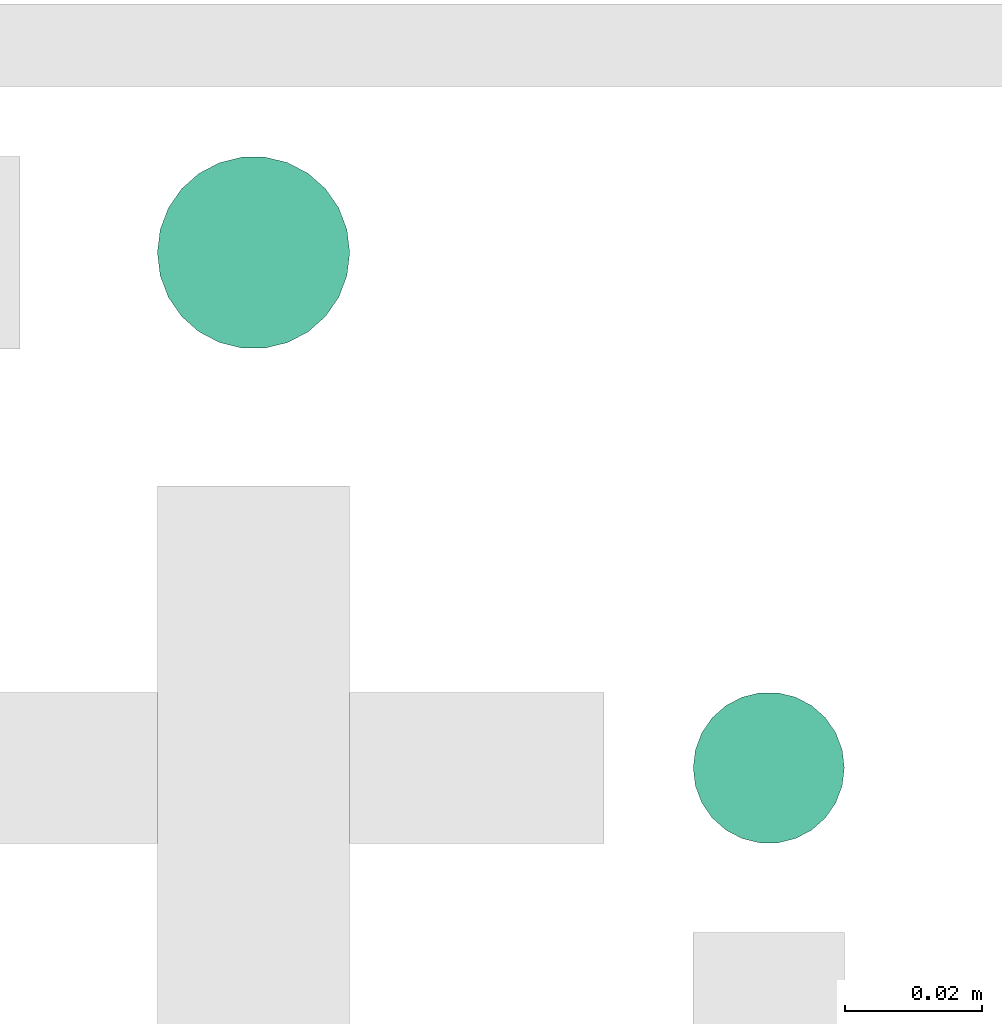
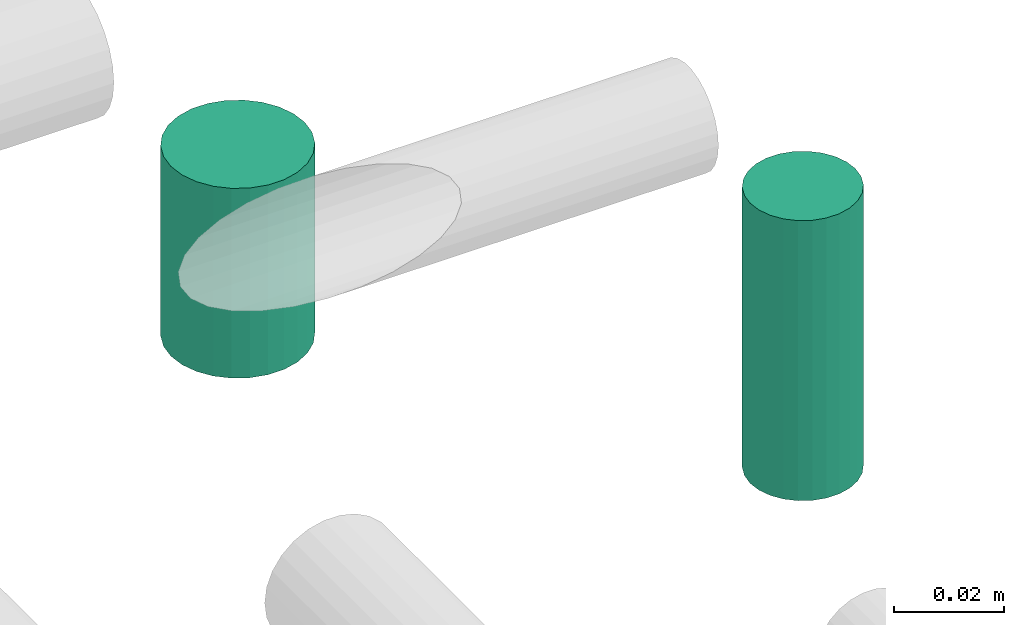
# One storey, part 312 of 331: 2 flow segments.
"""IFC2X3 building model written with IfcOpenShell, lengths in millimetres."""

from ifc_helpers import new_model, entity, si_unit, converted_unit, derived_unit, direction, frame, frame_2d, origin, origin_2d_with_axis, place, context, subcontext, project, spatial, circle, extrude, type_object, element, save


model = new_model("IFC2X3")

# Units and contexts
model_context = context("Model", 3, precision=0.01, world=origin(), true_north=direction((6.12303176911189e-17, 1.0)))
body_context = subcontext(model_context, "Body", "Model", "MODEL_VIEW")
ifc_project = project(units=[si_unit("LENGTHUNIT", "METRE", prefix="MILLI"), si_unit("AREAUNIT", "SQUARE_METRE"), si_unit("VOLUMEUNIT", "CUBIC_METRE"), converted_unit("PLANEANGLEUNIT", "DEGREE", entity("IfcRatioMeasure", 0.0174532925199433), si_unit("PLANEANGLEUNIT", "RADIAN"), dimensions=[0, 0, 0, 0, 0, 0, 0]), si_unit("MASSUNIT", "GRAM", prefix="KILO"), derived_unit("MASSDENSITYUNIT", [(si_unit("MASSUNIT", "GRAM", prefix="KILO"), 1), (si_unit("LENGTHUNIT", "METRE"), -3)]), derived_unit("MOMENTOFINERTIAUNIT", [(si_unit("LENGTHUNIT", "METRE"), 4)]), si_unit("TIMEUNIT", "SECOND"), si_unit("FREQUENCYUNIT", "HERTZ"), si_unit("THERMODYNAMICTEMPERATUREUNIT", "DEGREE_CELSIUS"), derived_unit("THERMALTRANSMITTANCEUNIT", [(si_unit("MASSUNIT", "GRAM", prefix="KILO"), 1), (si_unit("THERMODYNAMICTEMPERATUREUNIT", "KELVIN"), -1), (si_unit("TIMEUNIT", "SECOND"), -3)]), derived_unit("VOLUMETRICFLOWRATEUNIT", [(si_unit("LENGTHUNIT", "METRE"), 3), (si_unit("TIMEUNIT", "SECOND"), -1)]), derived_unit("MASSFLOWRATEUNIT", [(si_unit("MASSUNIT", "GRAM", prefix="KILO"), 1), (si_unit("TIMEUNIT", "SECOND"), -1)]), derived_unit("ROTATIONALFREQUENCYUNIT", [(si_unit("TIMEUNIT", "SECOND"), -1)]), si_unit("ELECTRICCURRENTUNIT", "AMPERE"), si_unit("ELECTRICVOLTAGEUNIT", "VOLT"), si_unit("POWERUNIT", "WATT"), si_unit("FORCEUNIT", "NEWTON", prefix="KILO"), si_unit("ILLUMINANCEUNIT", "LUX"), si_unit("LUMINOUSFLUXUNIT", "LUMEN"), si_unit("LUMINOUSINTENSITYUNIT", "CANDELA"), derived_unit("USERDEFINED", [(si_unit("MASSUNIT", "GRAM", prefix="KILO"), -1), (si_unit("LENGTHUNIT", "METRE"), -2), (si_unit("TIMEUNIT", "SECOND"), 3), (si_unit("LUMINOUSFLUXUNIT", "LUMEN"), 1)]), derived_unit("LINEARVELOCITYUNIT", [(si_unit("LENGTHUNIT", "METRE"), 1), (si_unit("TIMEUNIT", "SECOND"), -1)]), si_unit("PRESSUREUNIT", "PASCAL"), derived_unit("USERDEFINED", [(si_unit("LENGTHUNIT", "METRE"), -2), (si_unit("MASSUNIT", "GRAM", prefix="KILO"), 1), (si_unit("TIMEUNIT", "SECOND"), -2)]), derived_unit("LINEARFORCEUNIT", [(si_unit("MASSUNIT", "GRAM", prefix="KILO"), 1), (si_unit("LENGTHUNIT", "METRE"), 1), (si_unit("TIMEUNIT", "SECOND"), -2), (si_unit("LENGTHUNIT", "METRE"), -1)]), derived_unit("PLANARFORCEUNIT", [(si_unit("MASSUNIT", "GRAM", prefix="KILO"), 1), (si_unit("LENGTHUNIT", "METRE"), 1), (si_unit("TIMEUNIT", "SECOND"), -2), (si_unit("LENGTHUNIT", "METRE"), -2)])], contexts=[model_context])

# Site, building, storey
site_placement = place(None, frame((0.0, -0.00077364408347762, 0.0)))
site = spatial("IfcSite", under=ifc_project, at=site_placement, CompositionType="ELEMENT")
building_placement = place(site_placement, origin())
building = spatial("IfcBuilding", under=site, at=building_placement, CompositionType="ELEMENT")
storey_placement = place(building_placement, origin())
storey = spatial("IfcBuildingStorey", under=building, at=storey_placement, CompositionType="ELEMENT", Elevation=0.0)

# Flow segments
pipe_segment_type = type_object("IfcPipeSegmentType", PredefinedType="NOTDEFINED")
flow_segment_1_placement = place(storey_placement, frame((65559.5166110417, 8569.21546224655, 18484.0)))
element("IfcFlowSegment", 1, at=flow_segment_1_placement, inside=storey, type_object=pipe_segment_type, context=body_context, shape_type="SweptSolid", body=[
    extrude(circle(Radius=14.0, at=frame_2d((0.0, -1.08286712929839e-12), x_axis=(1.0, 0.0))), frame((15.5952722359127, 15.5952722359149, 0.0), z_axis=(0.0, 0.0, 1.0), x_axis=(-1.0, 0.0, 0.0)), (0.0, 0.0, 1.0), 41.9999999999948),
])
flow_segment_2_placement = place(storey_placement, frame((65637.5166110417, 8497.21546225977, 18473.9968494045)))
element("IfcFlowSegment", 2, at=flow_segment_2_placement, inside=storey, type_object=pipe_segment_type, context=body_context, shape_type="SweptSolid", body=[
    extrude(circle(Radius=11.0, at=origin_2d_with_axis()), frame((12.5952722359134, 12.5952722359156, 0.0), z_axis=(0.0, 0.0, 1.0), x_axis=(-1.0, 0.0, 0.0)), (0.0, 0.0, 1.0), 62.0031505955357),
])

save(model, "model.ifc")
